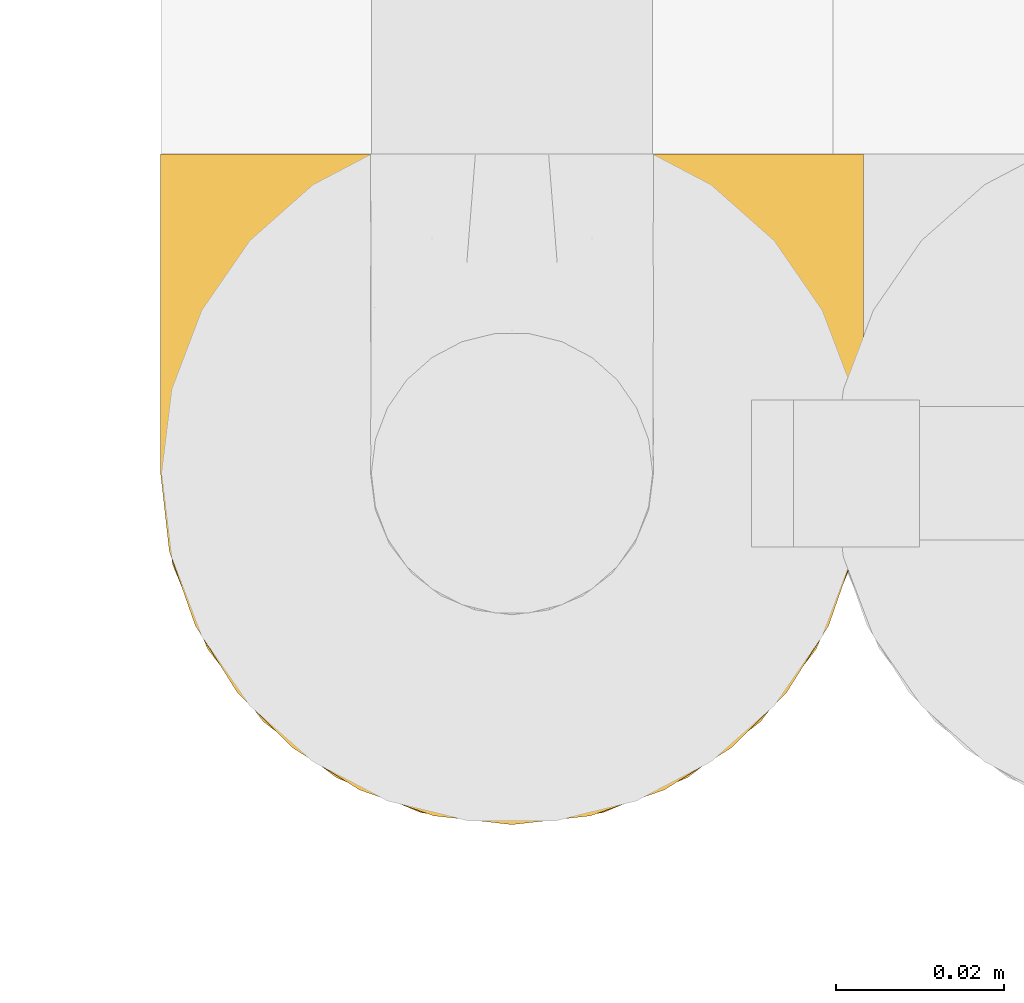
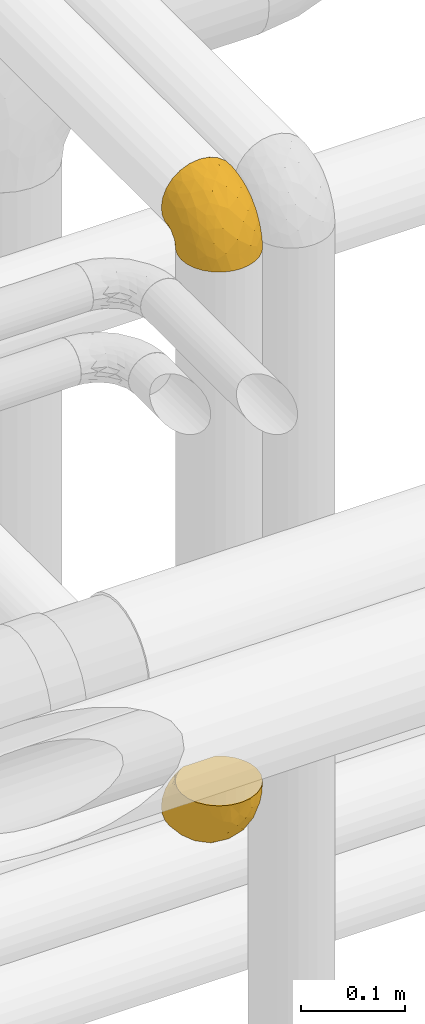
# One storey, part 424 of 827: 2 coverings.
"""IFC2X3 building model written with IfcOpenShell, lengths in millimetres."""

from ifc_helpers import new_model, entity, si_unit, converted_unit, derived_unit, direction, frame, origin, place, context, subcontext, project, spatial, faceted_brep, element, save


model = new_model("IFC2X3")

# Units and contexts
model_context = context("Model", 3, precision=0.01, world=origin(), true_north=direction((6.12303176911189e-17, 1.0)))
body_context = subcontext(model_context, "Body", "Model", "MODEL_VIEW")
ifc_project = project(units=[si_unit("LENGTHUNIT", "METRE", prefix="MILLI"), si_unit("AREAUNIT", "SQUARE_METRE"), si_unit("VOLUMEUNIT", "CUBIC_METRE"), converted_unit("PLANEANGLEUNIT", "DEGREE", entity("IfcRatioMeasure", 0.0174532925199433), si_unit("PLANEANGLEUNIT", "RADIAN"), dimensions=[0, 0, 0, 0, 0, 0, 0]), si_unit("MASSUNIT", "GRAM", prefix="KILO"), derived_unit("MASSDENSITYUNIT", [(si_unit("MASSUNIT", "GRAM", prefix="KILO"), 1), (si_unit("LENGTHUNIT", "METRE"), -3)]), derived_unit("MOMENTOFINERTIAUNIT", [(si_unit("LENGTHUNIT", "METRE"), 4)]), si_unit("TIMEUNIT", "SECOND"), si_unit("FREQUENCYUNIT", "HERTZ"), si_unit("THERMODYNAMICTEMPERATUREUNIT", "DEGREE_CELSIUS"), derived_unit("THERMALTRANSMITTANCEUNIT", [(si_unit("MASSUNIT", "GRAM", prefix="KILO"), 1), (si_unit("THERMODYNAMICTEMPERATUREUNIT", "KELVIN"), -1), (si_unit("TIMEUNIT", "SECOND"), -3)]), derived_unit("VOLUMETRICFLOWRATEUNIT", [(si_unit("LENGTHUNIT", "METRE"), 3), (si_unit("TIMEUNIT", "SECOND"), -1)]), derived_unit("MASSFLOWRATEUNIT", [(si_unit("MASSUNIT", "GRAM", prefix="KILO"), 1), (si_unit("TIMEUNIT", "SECOND"), -1)]), derived_unit("ROTATIONALFREQUENCYUNIT", [(si_unit("TIMEUNIT", "SECOND"), -1)]), si_unit("ELECTRICCURRENTUNIT", "AMPERE"), si_unit("ELECTRICVOLTAGEUNIT", "VOLT"), si_unit("POWERUNIT", "WATT"), si_unit("FORCEUNIT", "NEWTON", prefix="KILO"), si_unit("ILLUMINANCEUNIT", "LUX"), si_unit("LUMINOUSFLUXUNIT", "LUMEN"), si_unit("LUMINOUSINTENSITYUNIT", "CANDELA"), derived_unit("USERDEFINED", [(si_unit("MASSUNIT", "GRAM", prefix="KILO"), -1), (si_unit("LENGTHUNIT", "METRE"), -2), (si_unit("TIMEUNIT", "SECOND"), 3), (si_unit("LUMINOUSFLUXUNIT", "LUMEN"), 1)]), derived_unit("LINEARVELOCITYUNIT", [(si_unit("LENGTHUNIT", "METRE"), 1), (si_unit("TIMEUNIT", "SECOND"), -1)]), si_unit("PRESSUREUNIT", "PASCAL"), derived_unit("USERDEFINED", [(si_unit("LENGTHUNIT", "METRE"), -2), (si_unit("MASSUNIT", "GRAM", prefix="KILO"), 1), (si_unit("TIMEUNIT", "SECOND"), -2)]), derived_unit("LINEARFORCEUNIT", [(si_unit("MASSUNIT", "GRAM", prefix="KILO"), 1), (si_unit("LENGTHUNIT", "METRE"), 1), (si_unit("TIMEUNIT", "SECOND"), -2), (si_unit("LENGTHUNIT", "METRE"), -1)]), derived_unit("PLANARFORCEUNIT", [(si_unit("MASSUNIT", "GRAM", prefix="KILO"), 1), (si_unit("LENGTHUNIT", "METRE"), 1), (si_unit("TIMEUNIT", "SECOND"), -2), (si_unit("LENGTHUNIT", "METRE"), -2)])], contexts=[model_context])

# Site, building, storey
site_placement = place(None, origin())
site = spatial("IfcSite", under=ifc_project, at=site_placement, CompositionType="ELEMENT")
building_placement = place(site_placement, origin())
building = spatial("IfcBuilding", under=site, at=building_placement, CompositionType="ELEMENT")
storey_placement = place(building_placement, frame((0.0, 0.0, 28200.0)))
storey = spatial("IfcBuildingStorey", under=building, at=storey_placement, Name="08", CompositionType="ELEMENT", Elevation=28200.0)

# Coverings
covering_1_placement = place(storey_placement, frame((54568.74, 16245.12, 2960.49)))
element("IfcCovering", 1, at=covering_1_placement, inside=storey, Name=":ADSK_", ObjectType=":ADSK_", PredefinedType="INSULATION", context=body_context, shape_type="Brep", body=[
    faceted_brep([(81.15, 25.28, 1.6), (76.16, 17.35, 1.6), (69.53, 10.72, 1.6), (61.6, 5.74, 1.6), (52.75, 2.64, 1.6), (43.45, 1.6, 1.6), (34.13, 2.65, 1.6), (25.28, 5.74, 1.6), (17.35, 10.73, 1.6), (10.72, 17.36, 1.6), (5.74, 25.29, 1.6), (2.64, 34.14, 1.6), (1.6, 43.45, 1.6), (2.66, 52.82, 1.6), (5.79, 61.71, 1.6), (10.83, 69.67, 1.6), (17.53, 76.31, 1.6), (25.53, 81.27, 1.6), (26.45, 81.27, 1.6), (27.37, 81.27, 1.6), (28.17, 81.27, 1.6), (29.49, 81.27, 1.6), (30.81, 81.27, 1.6), (32.13, 81.27, 1.6), (33.45, 81.27, 1.6), (34.78, 81.27, 1.6), (36.1, 81.27, 1.6), (37.42, 81.27, 1.6), (38.74, 81.27, 1.6), (40.06, 81.27, 1.6), (41.38, 81.27, 1.6), (42.7, 81.27, 1.6), (44.02, 81.27, 1.6), (45.34, 81.27, 1.6), (46.66, 81.27, 1.6), (47.58, 81.27, 1.6), (48.5, 81.27, 1.6), (49.41, 81.27, 1.6), (50.33, 81.27, 1.6), (51.25, 81.27, 1.6), (52.17, 81.27, 1.6), (53.09, 81.27, 1.6), (54.01, 81.27, 1.6), (54.93, 81.27, 1.6), (55.85, 81.27, 1.6), (56.76, 81.27, 1.6), (57.68, 81.27, 1.6), (58.6, 81.27, 1.6), (59.52, 81.27, 1.6), (60.44, 81.27, 1.6), (61.36, 81.27, 1.6), (69.37, 76.3, 1.6), (76.07, 69.66, 1.6), (81.11, 61.69, 1.6), (84.24, 52.8, 1.6), (85.3, 43.45, 1.6), (84.24, 34.13, 1.6), (17.52, 81.45, 6.74), (10.83, 81.45, 13.37), (5.79, 81.45, 21.34), (2.66, 81.45, 30.23), (1.6, 81.45, 39.6), (3.02, 81.45, 50.43), (7.2, 81.45, 60.52), (13.85, 81.45, 69.19), (22.52, 81.45, 75.84), (32.61, 81.45, 80.02), (43.45, 81.45, 81.45), (54.28, 81.45, 80.02), (64.37, 81.45, 75.84), (73.04, 81.45, 69.19), (79.69, 81.45, 60.52), (83.87, 81.45, 50.43), (85.3, 81.45, 39.6), (84.23, 81.45, 30.23), (81.1, 81.45, 21.34), (76.06, 81.45, 13.37), (69.37, 81.45, 6.74), (61.36, 81.45, 1.77), (60.44, 81.45, 1.77), (59.12, 81.45, 1.77), (58.0, 81.45, 1.77), (56.88, 81.45, 1.77), (55.76, 81.45, 1.77), (54.64, 81.45, 1.77), (53.52, 81.45, 1.77), (52.4, 81.45, 1.77), (51.28, 81.45, 1.77), (50.16, 81.45, 1.77), (49.04, 81.45, 1.77), (47.92, 81.45, 1.77), (46.8, 81.45, 1.77), (45.68, 81.45, 1.77), (44.56, 81.45, 1.77), (43.45, 81.45, 1.77), (42.12, 81.45, 1.77), (40.8, 81.45, 1.77), (39.48, 81.45, 1.77), (38.16, 81.45, 1.77), (36.84, 81.45, 1.77), (35.52, 81.45, 1.77), (34.2, 81.45, 1.77), (32.88, 81.45, 1.77), (31.96, 81.45, 1.77), (31.05, 81.45, 1.77), (30.13, 81.45, 1.77), (29.21, 81.45, 1.77), (28.29, 81.45, 1.77), (27.37, 81.45, 1.77), (26.45, 81.45, 1.77), (25.53, 81.45, 1.77), (54.08, 81.33, 1.73), (55.16, 81.32, 1.72), (36.18, 81.33, 1.73), (35.13, 81.32, 1.72), (44.01, 81.33, 1.73), (45.08, 81.32, 1.73), (61.36, 81.32, 1.72), (59.98, 81.32, 1.72), (46.18, 81.32, 1.72), (26.74, 81.32, 1.72), (47.36, 81.32, 1.72), (29.67, 81.32, 1.73), (28.72, 81.34, 1.74), (39.77, 81.32, 1.72), (52.96, 81.31, 1.71), (51.84, 81.33, 1.73), (40.8, 81.31, 1.71), (41.87, 81.32, 1.72), (42.94, 81.33, 1.73), (27.77, 81.32, 1.72), (48.4, 81.33, 1.73), (37.21, 81.32, 1.72), (33.54, 81.33, 1.73), (32.49, 81.32, 1.72), (30.69, 81.32, 1.72), (50.69, 81.32, 1.72), (49.6, 81.31, 1.71), (56.32, 81.32, 1.72), (57.44, 81.33, 1.73), (58.88, 81.31, 1.71), (25.53, 81.32, 1.72), (61.36, 81.3, 1.68), (61.36, 81.29, 1.64), (25.53, 81.29, 1.64), (25.53, 81.3, 1.68), (61.36, 81.4, 1.75), (61.36, 81.36, 1.74), (25.53, 81.36, 1.74), (25.53, 81.4, 1.75), (31.59, 81.3, 1.7), (38.71, 81.33, 1.73), (3.97, 74.06, 24.54), (1.6, 45.99, 11.1), (3.97, 58.35, 8.47), (8.09, 67.76, 9.11), (8.09, 66.18, 4.86), (16.43, 76.46, 5.0), (15.73, 77.33, 6.81), (1.6, 71.95, 37.05), (10.79, 72.25, 9.03), (13.99, 78.91, 9.47), (8.08, 76.42, 16.39), (14.0, 73.52, 3.95), (12.83, 76.9, 9.9), (3.18, 65.25, 22.7), (1.6, 62.45, 34.5), (1.6, 74.31, 37.68), (3.28, 59.38, 15.82), (1.6, 48.54, 20.6), (6.28, 67.72, 14.37), (1.6, 55.49, 27.55), (19.06, 79.73, 5.2), (8.08, 73.23, 14.88), (1.6, 45.36, 8.73), (32.11, 15.81, 44.27), (29.62, 6.4, 20.94), (43.45, 7.67, 32.15), (2.45, 68.46, 46.13), (2.5, 59.33, 42.67), (9.73, 48.7, 55.18), (17.97, 53.94, 67.27), (10.24, 65.02, 62.91), (4.78, 60.77, 51.5), (4.78, 72.07, 54.79), (8.01, 26.25, 25.78), (8.01, 22.29, 13.05), (13.85, 16.0, 18.46), (2.42, 46.93, 32.4), (21.17, 14.19, 31.07), (35.73, 58.46, 77.32), (27.43, 61.51, 75.62), (43.45, 4.64, 16.9), (17.97, 68.93, 71.69), (35.71, 29.62, 61.4), (29.47, 24.85, 54.47), (3.41, 38.55, 27.66), (3.94, 31.27, 14.53), (21.17, 9.35, 15.56), (7.92, 37.15, 42.26), (4.25, 47.07, 41.51), (11.75, 26.49, 36.93), (18.31, 23.01, 42.72), (24.94, 19.4, 44.68), (28.78, 48.06, 71.2), (35.82, 42.46, 70.48), (43.45, 50.89, 75.37), (28.38, 35.78, 63.65), (43.45, 24.98, 58.06), (43.45, 16.33, 45.11), (43.45, 66.14, 78.4), (21.21, 30.96, 54.95), (16.48, 41.83, 59.31), (13.85, 33.28, 49.01), (43.45, 37.94, 66.71), (82.11, 67.39, 53.75), (51.41, 58.47, 77.27), (57.45, 32.5, 61.6), (54.78, 15.79, 44.24), (73.03, 15.99, 18.46), (65.7, 9.34, 15.55), (76.65, 56.91, 60.14), (68.92, 63.5, 70.5), (68.01, 44.08, 63.0), (78.88, 26.24, 25.78), (78.88, 22.27, 13.05), (82.94, 31.26, 14.53), (64.44, 23.95, 48.5), (84.49, 63.79, 44.23), (85.3, 62.45, 34.5), (85.3, 71.95, 37.05), (85.3, 45.36, 8.73), (57.84, 67.83, 77.68), (76.65, 70.28, 64.08), (51.19, 42.11, 70.25), (57.26, 6.39, 20.93), (78.14, 43.54, 49.9), (82.35, 58.03, 49.6), (65.7, 14.18, 31.06), (84.61, 56.34, 39.62), (84.36, 48.09, 34.42), (85.3, 48.54, 20.6), (85.3, 55.49, 27.55), (73.03, 21.78, 33.36), (83.48, 38.54, 27.68), (85.3, 45.99, 11.1), (84.54, 72.79, 46.67), (73.03, 33.26, 49.0), (79.54, 35.53, 38.94), (59.46, 53.66, 73.05), (73.5, 43.03, 56.63), (82.57, 49.68, 43.85), (82.92, 74.06, 24.54), (83.62, 59.37, 15.82), (82.92, 58.34, 8.47), (78.81, 67.75, 9.12), (72.9, 78.91, 9.47), (74.06, 76.9, 9.91), (78.81, 78.08, 16.85), (78.81, 73.23, 14.88), (67.83, 79.73, 5.2), (71.15, 77.34, 6.81), (72.91, 73.51, 3.96), (70.47, 76.45, 5.0), (78.81, 66.41, 5.86), (80.62, 67.7, 14.38), (76.11, 72.24, 9.04), (83.71, 65.25, 22.7)], [[[0, 1, 2, 3, 4, 5, 6, 7, 8, 9, 10, 11, 12, 13, 14, 15, 16, 17, 18, 19, 20, 21, 22, 23, 24, 25, 26, 27, 28, 29, 30, 31, 32, 33, 34, 35, 36, 37, 38, 39, 40, 41, 42, 43, 44, 45, 46, 47, 48, 49, 50, 51, 52, 53, 54, 55, 56]], [[57, 58, 59, 60, 61, 62, 63, 64, 65, 66, 67, 68, 69, 70, 71, 72, 73, 74, 75, 76, 77, 78, 79, 80, 81, 82, 83, 84, 85, 86, 87, 88, 89, 90, 91, 92, 93, 94, 95, 96, 97, 98, 99, 100, 101, 102, 103, 104, 105, 106, 107, 108, 109, 110]], [[111, 84, 112]], [[113, 26, 114]], [[114, 101, 100]], [[115, 93, 116]], [[79, 117, 118]], [[33, 116, 119]], [[117, 49, 118]], [[19, 18, 120]], [[119, 121, 34]], [[122, 21, 123]], [[97, 96, 124]], [[86, 125, 126]], [[116, 92, 119]], [[127, 96, 128]], [[32, 129, 115]], [[19, 120, 130]], [[121, 90, 131]], [[94, 115, 129]], [[115, 116, 32]], [[118, 49, 48]], [[113, 99, 132]], [[133, 114, 25]], [[24, 134, 133]], [[135, 22, 122]], [[136, 137, 88]], [[84, 83, 112]], [[138, 82, 139]], [[130, 20, 19]], [[118, 48, 140]], [[81, 140, 139]], [[123, 21, 20]], [[141, 120, 18]], [[139, 82, 81]], [[130, 107, 123]], [[49, 117, 142, 143, 50]], [[18, 17, 144, 145, 141]], [[79, 78, 146, 147, 117]], [[109, 141, 148, 149, 110]], [[102, 133, 134]], [[105, 135, 122]], [[118, 80, 79]], [[80, 118, 140]], [[120, 109, 108]], [[47, 46, 140, 48]], [[81, 80, 140]], [[44, 112, 138]], [[93, 115, 94]], [[46, 139, 140]], [[46, 45, 139]], [[139, 45, 138]], [[138, 112, 83]], [[85, 84, 111]], [[112, 43, 111]], [[83, 82, 138]], [[106, 122, 123]], [[105, 122, 106]], [[21, 122, 22]], [[124, 29, 28]], [[33, 32, 116]], [[128, 129, 31]], [[32, 31, 129]], [[34, 33, 119]], [[116, 93, 92]], [[129, 95, 94]], [[95, 129, 128]], [[41, 40, 125, 42]], [[119, 91, 121]], [[36, 35, 131, 37]], [[137, 131, 89]], [[121, 131, 35]], [[90, 121, 91]], [[119, 92, 91]], [[136, 126, 39]], [[125, 86, 85]], [[42, 125, 111]], [[85, 111, 125]], [[150, 23, 22]], [[130, 108, 107]], [[130, 123, 20]], [[107, 106, 123]], [[137, 37, 131]], [[136, 38, 137]], [[89, 88, 137]], [[131, 90, 89]], [[124, 151, 97]], [[40, 39, 126]], [[87, 126, 136]], [[86, 126, 87]], [[136, 88, 87]], [[40, 126, 125]], [[39, 38, 136]], [[95, 128, 96]], [[30, 128, 31]], [[29, 124, 127]], [[127, 128, 30]], [[151, 124, 28]], [[127, 30, 29]], [[127, 124, 96]], [[151, 98, 97]], [[45, 44, 138]], [[26, 113, 132]], [[113, 100, 99]], [[132, 151, 27]], [[27, 26, 132]], [[26, 25, 114]], [[100, 113, 114]], [[101, 133, 102]], [[133, 101, 114]], [[28, 27, 151]], [[132, 99, 98]], [[23, 134, 24]], [[25, 24, 133]], [[134, 23, 150]], [[135, 104, 150]], [[150, 104, 103]], [[103, 102, 134]], [[130, 120, 108]], [[109, 120, 141]], [[42, 111, 43]], [[112, 44, 43]], [[104, 135, 105]], [[134, 150, 103]], [[135, 150, 22]], [[35, 34, 121]], [[137, 38, 37]], [[98, 151, 132]], [[59, 152, 60]], [[13, 153, 154]], [[155, 156, 154]], [[157, 158, 141]], [[159, 60, 152]], [[160, 157, 155]], [[161, 162, 58]], [[58, 162, 59]], [[144, 16, 163]], [[58, 57, 161]], [[162, 161, 164]], [[157, 163, 155]], [[163, 16, 15]], [[57, 149, 161]], [[152, 165, 166]], [[157, 144, 163]], [[60, 159, 167, 61]], [[156, 14, 154]], [[163, 156, 155]], [[155, 154, 168]], [[168, 154, 169]], [[155, 170, 160]], [[57, 110, 149]], [[144, 17, 16]], [[156, 15, 14]], [[171, 165, 168]], [[158, 164, 172]], [[14, 13, 154]], [[157, 141, 145, 144]], [[173, 164, 158]], [[173, 160, 170]], [[171, 166, 165]], [[168, 165, 170]], [[168, 169, 171]], [[152, 173, 165]], [[170, 155, 168]], [[165, 173, 170]], [[160, 173, 158]], [[172, 149, 148]], [[148, 141, 158]], [[158, 157, 160]], [[152, 166, 159]], [[173, 152, 162]], [[59, 162, 152]], [[13, 12, 174, 153]], [[153, 169, 154]], [[15, 156, 163]], [[162, 164, 173]], [[172, 164, 161]], [[149, 172, 161]], [[158, 172, 148]], [[175, 176, 177]], [[178, 166, 179]], [[180, 181, 182]], [[183, 184, 178]], [[185, 186, 187]], [[171, 188, 179]], [[174, 12, 11]], [[189, 176, 175]], [[190, 66, 191]], [[176, 6, 192]], [[193, 65, 64]], [[63, 184, 182]], [[63, 182, 64]], [[65, 193, 191]], [[184, 63, 62]], [[175, 194, 195]], [[196, 169, 197]], [[174, 11, 197]], [[8, 7, 198]], [[187, 9, 8]], [[197, 169, 153, 174]], [[197, 11, 10]], [[186, 197, 10]], [[199, 180, 200]], [[197, 185, 196]], [[201, 189, 202]], [[201, 187, 189]], [[195, 203, 175]], [[191, 204, 190]], [[176, 7, 6]], [[177, 176, 192]], [[189, 198, 176]], [[65, 191, 66]], [[198, 187, 8]], [[205, 206, 190]], [[9, 186, 10]], [[181, 207, 204]], [[208, 175, 177, 209]], [[66, 190, 210]], [[211, 212, 213]], [[190, 204, 205]], [[180, 182, 183]], [[193, 182, 181]], [[62, 61, 167]], [[196, 185, 199]], [[196, 200, 188]], [[6, 5, 192]], [[176, 198, 7]], [[187, 198, 189]], [[187, 186, 9]], [[197, 186, 185]], [[200, 180, 183]], [[180, 213, 212]], [[179, 183, 178]], [[185, 201, 199]], [[210, 190, 206]], [[210, 67, 66]], [[205, 204, 207]], [[194, 205, 207]], [[194, 214, 205]], [[195, 194, 207]], [[208, 194, 175]], [[207, 211, 195]], [[202, 203, 211]], [[212, 207, 181]], [[202, 211, 213]], [[201, 202, 213]], [[189, 175, 203]], [[199, 201, 213]], [[187, 201, 185]], [[180, 199, 213]], [[196, 199, 200]], [[211, 203, 195]], [[189, 203, 202]], [[207, 212, 211]], [[180, 212, 181]], [[214, 194, 208]], [[214, 206, 205]], [[196, 188, 169]], [[181, 204, 191]], [[182, 193, 64]], [[191, 193, 181]], [[178, 62, 167]], [[182, 184, 183]], [[62, 178, 184]], [[178, 167, 159, 166]], [[171, 179, 166]], [[200, 183, 179]], [[179, 188, 200]], [[169, 188, 171]], [[71, 215, 72]], [[206, 216, 210]], [[217, 208, 218]], [[216, 68, 210]], [[219, 220, 2]], [[221, 222, 223]], [[224, 225, 226]], [[227, 223, 217]], [[228, 229, 230]], [[56, 231, 226]], [[232, 222, 69]], [[56, 55, 231]], [[70, 233, 71]], [[71, 233, 215]], [[0, 56, 226]], [[208, 217, 234]], [[218, 177, 235]], [[221, 236, 237]], [[238, 220, 219]], [[1, 219, 2]], [[68, 216, 232]], [[235, 3, 220]], [[235, 192, 4]], [[1, 0, 225]], [[228, 239, 229]], [[240, 241, 242]], [[243, 238, 219]], [[224, 226, 244]], [[226, 241, 244]], [[3, 235, 4]], [[69, 222, 70]], [[225, 219, 1]], [[218, 235, 238]], [[243, 219, 224]], [[218, 227, 217]], [[3, 2, 220]], [[218, 208, 209, 177]], [[226, 231, 245, 241]], [[215, 228, 246]], [[247, 248, 236]], [[248, 224, 244]], [[223, 222, 249]], [[233, 222, 221]], [[242, 239, 240]], [[248, 247, 243]], [[217, 223, 249]], [[250, 247, 236]], [[216, 234, 249]], [[218, 238, 227]], [[192, 235, 177]], [[192, 5, 4]], [[72, 246, 73]], [[235, 220, 238]], [[226, 225, 0]], [[219, 225, 224]], [[240, 248, 244]], [[239, 242, 229]], [[236, 248, 251]], [[68, 67, 210]], [[234, 216, 206]], [[216, 249, 232]], [[234, 206, 214, 208]], [[249, 234, 217]], [[222, 232, 249]], [[69, 68, 232]], [[246, 228, 230]], [[237, 228, 215]], [[243, 227, 238]], [[223, 227, 247]], [[73, 246, 230]], [[215, 246, 72]], [[248, 243, 224]], [[227, 243, 247]], [[237, 236, 251]], [[250, 221, 223]], [[222, 233, 70]], [[215, 233, 221]], [[221, 237, 215]], [[239, 237, 251]], [[237, 239, 228]], [[239, 251, 240]], [[248, 240, 251]], [[241, 240, 244]], [[221, 250, 236]], [[223, 247, 250]], [[74, 230, 252]], [[253, 254, 255]], [[146, 77, 256]], [[257, 258, 259]], [[260, 256, 257]], [[260, 261, 147]], [[75, 74, 252]], [[51, 143, 262]], [[263, 143, 142, 117]], [[256, 77, 76]], [[252, 258, 75]], [[253, 241, 254]], [[254, 245, 54]], [[258, 256, 76]], [[53, 52, 264]], [[255, 265, 253]], [[254, 264, 255]], [[255, 264, 262]], [[75, 258, 76]], [[265, 255, 266]], [[255, 262, 263]], [[51, 50, 143]], [[54, 245, 231, 55]], [[51, 262, 52]], [[253, 267, 242]], [[254, 54, 53]], [[266, 259, 265]], [[146, 78, 77]], [[263, 117, 261]], [[146, 256, 260]], [[257, 259, 261]], [[267, 253, 265]], [[229, 267, 252]], [[242, 267, 229]], [[242, 241, 253]], [[252, 267, 259]], [[255, 263, 266]], [[259, 267, 265]], [[261, 117, 147]], [[263, 261, 266]], [[259, 266, 261]], [[230, 74, 73]], [[230, 229, 252]], [[259, 258, 252]], [[254, 241, 245]], [[53, 264, 254]], [[52, 262, 264]], [[143, 263, 262]], [[258, 257, 256]], [[261, 260, 257]], [[146, 260, 147]]]),
])
covering_2_placement = place(storey_placement, frame((54568.74, 16245.12, 2256.64)))
element("IfcCovering", 2, at=covering_2_placement, inside=storey, Name=":ADSK_", ObjectType=":ADSK_", PredefinedType="INSULATION", context=body_context, shape_type="Brep", body=[
    faceted_brep([(81.15, 81.45, 25.28), (76.16, 81.45, 17.35), (69.53, 81.45, 10.72), (61.6, 81.45, 5.74), (52.75, 81.45, 2.64), (43.45, 81.45, 1.6), (34.13, 81.45, 2.65), (25.28, 81.45, 5.74), (17.35, 81.45, 10.73), (10.72, 81.45, 17.36), (5.74, 81.45, 25.29), (2.64, 81.45, 34.14), (1.6, 81.45, 43.45), (2.66, 81.45, 52.82), (5.79, 81.45, 61.71), (10.83, 81.45, 69.67), (17.53, 81.45, 76.31), (25.53, 81.45, 81.27), (26.45, 81.45, 81.27), (27.37, 81.45, 81.27), (28.17, 81.45, 81.27), (29.49, 81.45, 81.27), (30.81, 81.45, 81.27), (32.13, 81.45, 81.27), (33.45, 81.45, 81.27), (34.78, 81.45, 81.27), (36.1, 81.45, 81.27), (37.42, 81.45, 81.27), (38.74, 81.45, 81.27), (40.06, 81.45, 81.27), (41.38, 81.45, 81.27), (42.7, 81.45, 81.27), (44.02, 81.45, 81.27), (45.34, 81.45, 81.27), (46.66, 81.45, 81.27), (47.58, 81.45, 81.27), (48.5, 81.45, 81.27), (49.41, 81.45, 81.27), (50.33, 81.45, 81.27), (51.25, 81.45, 81.27), (52.17, 81.45, 81.27), (53.09, 81.45, 81.27), (54.01, 81.45, 81.27), (54.93, 81.45, 81.27), (55.85, 81.45, 81.27), (56.76, 81.45, 81.27), (57.68, 81.45, 81.27), (58.6, 81.45, 81.27), (59.52, 81.45, 81.27), (60.44, 81.45, 81.27), (61.36, 81.45, 81.27), (69.37, 81.45, 76.3), (76.07, 81.45, 69.66), (81.11, 81.45, 61.69), (84.24, 81.45, 52.8), (85.3, 81.45, 43.45), (84.24, 81.45, 34.13), (17.52, 76.3, 81.45), (10.83, 69.67, 81.45), (5.79, 61.7, 81.45), (2.66, 52.81, 81.45), (1.6, 43.45, 81.45), (3.02, 32.61, 81.45), (7.2, 22.52, 81.45), (13.85, 13.85, 81.45), (22.52, 7.2, 81.45), (32.61, 3.02, 81.45), (43.45, 1.6, 81.45), (54.28, 3.02, 81.45), (64.37, 7.2, 81.45), (73.04, 13.85, 81.45), (79.69, 22.52, 81.45), (83.87, 32.61, 81.45), (85.3, 43.45, 81.45), (84.23, 52.81, 81.45), (81.1, 61.7, 81.45), (76.06, 69.67, 81.45), (69.37, 76.3, 81.45), (61.36, 81.27, 81.45), (60.44, 81.27, 81.45), (59.12, 81.27, 81.45), (58.0, 81.27, 81.45), (56.88, 81.27, 81.45), (55.76, 81.27, 81.45), (54.64, 81.27, 81.45), (53.52, 81.27, 81.45), (52.4, 81.27, 81.45), (51.28, 81.27, 81.45), (50.16, 81.27, 81.45), (49.04, 81.27, 81.45), (47.92, 81.27, 81.45), (46.8, 81.27, 81.45), (45.68, 81.27, 81.45), (44.56, 81.27, 81.45), (43.45, 81.27, 81.45), (42.12, 81.27, 81.45), (40.8, 81.27, 81.45), (39.48, 81.27, 81.45), (38.16, 81.27, 81.45), (36.84, 81.27, 81.45), (35.52, 81.27, 81.45), (34.2, 81.27, 81.45), (32.88, 81.27, 81.45), (31.96, 81.27, 81.45), (31.05, 81.27, 81.45), (30.13, 81.27, 81.45), (29.21, 81.27, 81.45), (28.29, 81.27, 81.45), (27.37, 81.27, 81.45), (26.45, 81.27, 81.45), (25.53, 81.27, 81.45), (54.08, 81.31, 81.33), (55.16, 81.33, 81.32), (36.18, 81.31, 81.33), (35.13, 81.32, 81.32), (44.01, 81.31, 81.33), (45.08, 81.32, 81.32), (61.36, 81.32, 81.32), (59.98, 81.32, 81.32), (46.18, 81.32, 81.32), (26.74, 81.32, 81.32), (47.36, 81.32, 81.32), (29.67, 81.32, 81.32), (28.72, 81.3, 81.34), (39.77, 81.32, 81.32), (52.96, 81.33, 81.31), (51.84, 81.31, 81.33), (40.8, 81.33, 81.31), (41.87, 81.32, 81.32), (42.94, 81.32, 81.33), (27.77, 81.32, 81.32), (48.4, 81.31, 81.33), (37.21, 81.32, 81.32), (33.54, 81.31, 81.33), (32.49, 81.32, 81.32), (30.69, 81.32, 81.32), (50.69, 81.32, 81.32), (49.6, 81.33, 81.31), (56.32, 81.32, 81.32), (57.44, 81.31, 81.33), (58.88, 81.33, 81.31), (25.53, 81.32, 81.32), (61.36, 81.36, 81.3), (61.36, 81.4, 81.29), (25.53, 81.4, 81.29), (25.53, 81.36, 81.3), (61.36, 81.29, 81.4), (61.36, 81.3, 81.36), (25.53, 81.3, 81.36), (25.53, 81.29, 81.4), (31.59, 81.35, 81.3), (38.71, 81.31, 81.33), (3.97, 58.5, 74.06), (1.6, 71.95, 45.99), (3.97, 74.57, 58.35), (8.09, 73.93, 67.76), (8.09, 78.18, 66.18), (16.43, 78.04, 76.46), (15.73, 76.23, 77.33), (1.6, 45.99, 71.95), (10.79, 74.01, 72.25), (13.99, 73.57, 78.91), (8.08, 66.66, 76.42), (14.0, 79.09, 73.52), (12.83, 73.14, 76.9), (3.18, 60.34, 65.25), (1.6, 48.54, 62.45), (1.6, 45.36, 74.31), (3.28, 67.22, 59.38), (1.6, 62.45, 48.54), (6.28, 68.67, 67.72), (1.6, 55.49, 55.49), (19.06, 77.84, 79.73), (8.08, 68.16, 73.23), (1.6, 74.31, 45.36), (32.11, 38.78, 15.81), (29.62, 62.1, 6.4), (43.45, 50.89, 7.67), (2.45, 36.91, 68.46), (2.5, 40.37, 59.33), (9.73, 27.86, 48.7), (17.97, 15.77, 53.94), (10.24, 20.13, 65.02), (4.78, 31.54, 60.77), (4.78, 28.25, 72.07), (8.01, 57.26, 26.25), (8.01, 69.99, 22.29), (13.85, 64.58, 16.0), (2.42, 50.64, 46.93), (21.17, 51.97, 14.19), (35.73, 5.72, 58.46), (27.43, 7.42, 61.51), (43.45, 66.14, 4.64), (17.97, 11.35, 68.93), (35.71, 21.64, 29.62), (29.47, 28.57, 24.85), (3.41, 55.38, 38.55), (3.94, 68.51, 31.27), (21.17, 67.48, 9.35), (7.92, 40.78, 37.15), (4.25, 41.53, 47.07), (11.75, 46.11, 26.49), (18.31, 40.32, 23.01), (24.94, 38.36, 19.4), (28.78, 11.84, 48.06), (35.82, 12.56, 42.46), (43.45, 7.67, 50.89), (28.38, 19.39, 35.78), (43.45, 24.98, 24.98), (43.45, 37.94, 16.33), (43.45, 4.64, 66.14), (21.21, 28.09, 30.96), (16.48, 23.73, 41.83), (13.85, 34.03, 33.28), (43.45, 16.33, 37.94), (82.11, 29.29, 67.39), (51.41, 5.77, 58.47), (57.45, 21.44, 32.5), (54.78, 38.8, 15.79), (73.03, 64.58, 15.99), (65.7, 67.49, 9.34), (76.65, 22.9, 56.91), (68.92, 12.54, 63.5), (68.01, 20.04, 44.08), (78.88, 57.26, 26.24), (78.88, 69.99, 22.27), (82.94, 68.51, 31.26), (64.44, 34.54, 23.95), (84.49, 38.81, 63.79), (85.3, 48.54, 62.45), (85.3, 45.99, 71.95), (85.3, 74.31, 45.36), (57.84, 5.36, 67.83), (76.65, 18.96, 70.28), (51.19, 12.79, 42.11), (57.26, 62.11, 6.39), (78.14, 33.14, 43.54), (82.35, 33.44, 58.03), (65.7, 51.98, 14.18), (84.61, 43.42, 56.34), (84.36, 48.62, 48.09), (85.3, 62.45, 48.54), (85.3, 55.49, 55.49), (73.03, 49.68, 21.78), (83.48, 55.37, 38.54), (85.3, 71.95, 45.99), (84.54, 36.37, 72.79), (73.03, 34.04, 33.26), (79.54, 44.1, 35.53), (59.46, 9.99, 53.66), (73.5, 26.41, 43.03), (82.57, 39.19, 49.68), (82.92, 58.5, 74.06), (83.62, 67.22, 59.37), (82.92, 74.57, 58.34), (78.81, 73.92, 67.75), (72.9, 73.57, 78.91), (74.06, 73.14, 76.9), (78.81, 66.19, 78.08), (78.81, 68.16, 73.23), (67.83, 77.84, 79.73), (71.15, 76.23, 77.34), (72.91, 79.08, 73.51), (70.47, 78.04, 76.45), (78.81, 77.18, 66.41), (80.62, 68.66, 67.7), (76.11, 74.0, 72.24), (83.71, 60.34, 65.25)], [[[0, 1, 2, 3, 4, 5, 6, 7, 8, 9, 10, 11, 12, 13, 14, 15, 16, 17, 18, 19, 20, 21, 22, 23, 24, 25, 26, 27, 28, 29, 30, 31, 32, 33, 34, 35, 36, 37, 38, 39, 40, 41, 42, 43, 44, 45, 46, 47, 48, 49, 50, 51, 52, 53, 54, 55, 56]], [[57, 58, 59, 60, 61, 62, 63, 64, 65, 66, 67, 68, 69, 70, 71, 72, 73, 74, 75, 76, 77, 78, 79, 80, 81, 82, 83, 84, 85, 86, 87, 88, 89, 90, 91, 92, 93, 94, 95, 96, 97, 98, 99, 100, 101, 102, 103, 104, 105, 106, 107, 108, 109, 110]], [[111, 84, 112]], [[113, 26, 114]], [[114, 101, 100]], [[115, 93, 116]], [[79, 117, 118]], [[33, 116, 119]], [[117, 49, 118]], [[19, 18, 120]], [[119, 121, 34]], [[122, 21, 123]], [[97, 96, 124]], [[86, 125, 126]], [[116, 92, 119]], [[127, 96, 128]], [[32, 129, 115]], [[19, 120, 130]], [[121, 90, 131]], [[94, 115, 129]], [[115, 116, 32]], [[118, 49, 48]], [[113, 99, 132]], [[133, 114, 25]], [[24, 134, 133]], [[135, 22, 122]], [[136, 137, 88]], [[84, 83, 112]], [[138, 82, 139]], [[130, 20, 19]], [[118, 48, 140]], [[81, 140, 139]], [[123, 21, 20]], [[141, 120, 18]], [[139, 82, 81]], [[130, 107, 123]], [[49, 117, 142, 143, 50]], [[18, 17, 144, 145, 141]], [[79, 78, 146, 147, 117]], [[109, 141, 148, 149, 110]], [[102, 133, 134]], [[105, 135, 122]], [[118, 80, 79]], [[80, 118, 140]], [[120, 109, 108]], [[47, 46, 140, 48]], [[81, 80, 140]], [[44, 112, 138]], [[93, 115, 94]], [[46, 139, 140]], [[46, 45, 139]], [[139, 45, 138]], [[138, 112, 83]], [[85, 84, 111]], [[112, 43, 111]], [[83, 82, 138]], [[106, 122, 123]], [[105, 122, 106]], [[21, 122, 22]], [[124, 29, 28]], [[33, 32, 116]], [[128, 129, 31]], [[32, 31, 129]], [[34, 33, 119]], [[116, 93, 92]], [[129, 95, 94]], [[95, 129, 128]], [[41, 40, 125, 42]], [[119, 91, 121]], [[36, 35, 131, 37]], [[137, 131, 89]], [[121, 131, 35]], [[90, 121, 91]], [[119, 92, 91]], [[136, 126, 39]], [[125, 86, 85]], [[42, 125, 111]], [[85, 111, 125]], [[150, 23, 22]], [[130, 108, 107]], [[130, 123, 20]], [[107, 106, 123]], [[137, 37, 131]], [[136, 38, 137]], [[89, 88, 137]], [[131, 90, 89]], [[124, 151, 97]], [[40, 39, 126]], [[87, 126, 136]], [[86, 126, 87]], [[136, 88, 87]], [[40, 126, 125]], [[39, 38, 136]], [[95, 128, 96]], [[30, 128, 31]], [[29, 124, 127]], [[127, 128, 30]], [[151, 124, 28]], [[127, 30, 29]], [[127, 124, 96]], [[151, 98, 97]], [[45, 44, 138]], [[26, 113, 132]], [[113, 100, 99]], [[132, 151, 27]], [[27, 26, 132]], [[26, 25, 114]], [[100, 113, 114]], [[101, 133, 102]], [[133, 101, 114]], [[28, 27, 151]], [[132, 99, 98]], [[23, 134, 24]], [[25, 24, 133]], [[134, 23, 150]], [[135, 104, 150]], [[150, 104, 103]], [[103, 102, 134]], [[130, 120, 108]], [[109, 120, 141]], [[42, 111, 43]], [[112, 44, 43]], [[104, 135, 105]], [[134, 150, 103]], [[135, 150, 22]], [[35, 34, 121]], [[137, 38, 37]], [[98, 151, 132]], [[59, 152, 60]], [[13, 153, 154]], [[155, 156, 154]], [[157, 158, 141]], [[159, 60, 152]], [[160, 157, 155]], [[161, 162, 58]], [[58, 162, 59]], [[144, 16, 163]], [[58, 57, 161]], [[162, 161, 164]], [[157, 163, 155]], [[163, 16, 15]], [[57, 149, 161]], [[152, 165, 166]], [[157, 144, 163]], [[60, 159, 167, 61]], [[156, 14, 154]], [[163, 156, 155]], [[155, 154, 168]], [[168, 154, 169]], [[155, 170, 160]], [[57, 110, 149]], [[144, 17, 16]], [[156, 15, 14]], [[171, 165, 168]], [[158, 164, 172]], [[14, 13, 154]], [[157, 145, 144]], [[173, 164, 158]], [[173, 160, 170]], [[171, 166, 165]], [[168, 165, 170]], [[168, 169, 171]], [[152, 173, 165]], [[170, 155, 168]], [[165, 173, 170]], [[160, 173, 158]], [[172, 149, 148]], [[148, 141, 158]], [[158, 157, 160]], [[152, 166, 159]], [[173, 152, 162]], [[59, 162, 152]], [[13, 12, 174, 153]], [[153, 169, 154]], [[15, 156, 163]], [[157, 141, 145]], [[162, 164, 173]], [[172, 164, 161]], [[149, 172, 161]], [[158, 172, 148]], [[175, 176, 177]], [[178, 166, 179]], [[180, 181, 182]], [[183, 184, 178]], [[185, 186, 187]], [[171, 188, 179]], [[174, 12, 11]], [[189, 176, 175]], [[190, 66, 191]], [[176, 6, 192]], [[193, 65, 64]], [[63, 184, 182]], [[63, 182, 64]], [[65, 193, 191]], [[184, 63, 62]], [[175, 194, 195]], [[196, 169, 197]], [[174, 11, 197]], [[8, 7, 198]], [[187, 9, 8]], [[197, 169, 153, 174]], [[197, 11, 10]], [[186, 197, 10]], [[199, 180, 200]], [[197, 185, 196]], [[201, 189, 202]], [[201, 187, 189]], [[195, 203, 175]], [[191, 204, 190]], [[176, 7, 6]], [[177, 176, 192]], [[189, 198, 176]], [[65, 191, 66]], [[198, 187, 8]], [[205, 206, 190]], [[9, 186, 10]], [[181, 207, 204]], [[208, 175, 177, 209]], [[66, 190, 210]], [[211, 212, 213]], [[190, 204, 205]], [[180, 182, 183]], [[193, 182, 181]], [[62, 61, 167]], [[196, 185, 199]], [[196, 200, 188]], [[6, 5, 192]], [[176, 198, 7]], [[187, 198, 189]], [[187, 186, 9]], [[197, 186, 185]], [[200, 180, 183]], [[180, 213, 212]], [[179, 183, 178]], [[185, 201, 199]], [[210, 190, 206]], [[210, 67, 66]], [[205, 204, 207]], [[194, 205, 207]], [[194, 214, 205]], [[195, 194, 207]], [[208, 194, 175]], [[207, 211, 195]], [[202, 203, 211]], [[212, 207, 181]], [[202, 211, 213]], [[201, 202, 213]], [[189, 175, 203]], [[199, 201, 213]], [[187, 201, 185]], [[180, 199, 213]], [[196, 199, 200]], [[211, 203, 195]], [[189, 203, 202]], [[207, 212, 211]], [[180, 212, 181]], [[214, 194, 208]], [[214, 206, 205]], [[196, 188, 169]], [[181, 204, 191]], [[182, 193, 64]], [[191, 193, 181]], [[178, 62, 167]], [[182, 184, 183]], [[62, 178, 184]], [[178, 167, 159, 166]], [[171, 179, 166]], [[200, 183, 179]], [[179, 188, 200]], [[169, 188, 171]], [[71, 215, 72]], [[206, 216, 210]], [[217, 208, 218]], [[216, 68, 210]], [[219, 220, 2]], [[221, 222, 223]], [[224, 225, 226]], [[227, 223, 217]], [[228, 229, 230]], [[56, 231, 226]], [[232, 222, 69]], [[56, 55, 231]], [[70, 233, 71]], [[71, 233, 215]], [[0, 56, 226]], [[208, 217, 234]], [[218, 177, 235]], [[221, 236, 237]], [[238, 220, 219]], [[1, 219, 2]], [[68, 216, 232]], [[235, 3, 220]], [[235, 192, 4]], [[1, 0, 225]], [[228, 239, 229]], [[240, 241, 242]], [[243, 238, 219]], [[224, 226, 244]], [[226, 241, 244]], [[3, 235, 4]], [[69, 222, 70]], [[225, 219, 1]], [[218, 235, 238]], [[243, 219, 224]], [[218, 227, 217]], [[3, 2, 220]], [[218, 208, 209, 177]], [[226, 231, 245, 241]], [[215, 228, 246]], [[247, 248, 236]], [[248, 224, 244]], [[223, 222, 249]], [[233, 222, 221]], [[242, 239, 240]], [[248, 247, 243]], [[217, 223, 249]], [[250, 247, 236]], [[216, 234, 249]], [[218, 238, 227]], [[192, 235, 177]], [[192, 5, 4]], [[72, 246, 73]], [[235, 220, 238]], [[226, 225, 0]], [[219, 225, 224]], [[240, 248, 244]], [[239, 242, 229]], [[236, 248, 251]], [[68, 67, 210]], [[234, 216, 206]], [[216, 249, 232]], [[234, 206, 214, 208]], [[249, 234, 217]], [[222, 232, 249]], [[69, 68, 232]], [[246, 228, 230]], [[237, 228, 215]], [[243, 227, 238]], [[223, 227, 247]], [[73, 246, 230]], [[215, 246, 72]], [[248, 243, 224]], [[227, 243, 247]], [[237, 236, 251]], [[250, 221, 223]], [[222, 233, 70]], [[215, 233, 221]], [[221, 237, 215]], [[239, 237, 251]], [[237, 239, 228]], [[239, 251, 240]], [[248, 240, 251]], [[241, 240, 244]], [[221, 250, 236]], [[223, 247, 250]], [[74, 230, 252]], [[253, 254, 255]], [[146, 77, 256]], [[257, 258, 259]], [[260, 256, 257]], [[260, 261, 147]], [[75, 74, 252]], [[51, 143, 262]], [[263, 143, 142, 117]], [[256, 77, 76]], [[252, 258, 75]], [[253, 241, 254]], [[254, 245, 54]], [[258, 256, 76]], [[53, 52, 264]], [[255, 265, 253]], [[254, 264, 255]], [[255, 264, 262]], [[75, 258, 76]], [[265, 255, 266]], [[255, 262, 263]], [[51, 50, 143]], [[54, 245, 231, 55]], [[51, 262, 52]], [[253, 267, 242]], [[254, 54, 53]], [[266, 259, 265]], [[146, 78, 77]], [[263, 117, 261]], [[146, 256, 260]], [[257, 259, 261]], [[267, 253, 265]], [[229, 267, 252]], [[242, 267, 229]], [[242, 241, 253]], [[252, 267, 259]], [[255, 263, 266]], [[259, 267, 265]], [[261, 117, 147]], [[263, 261, 266]], [[259, 266, 261]], [[230, 74, 73]], [[230, 229, 252]], [[259, 258, 252]], [[254, 241, 245]], [[53, 264, 254]], [[52, 262, 264]], [[143, 263, 262]], [[258, 257, 256]], [[261, 260, 257]], [[146, 260, 147]]]),
])

save(model, "model.ifc")
